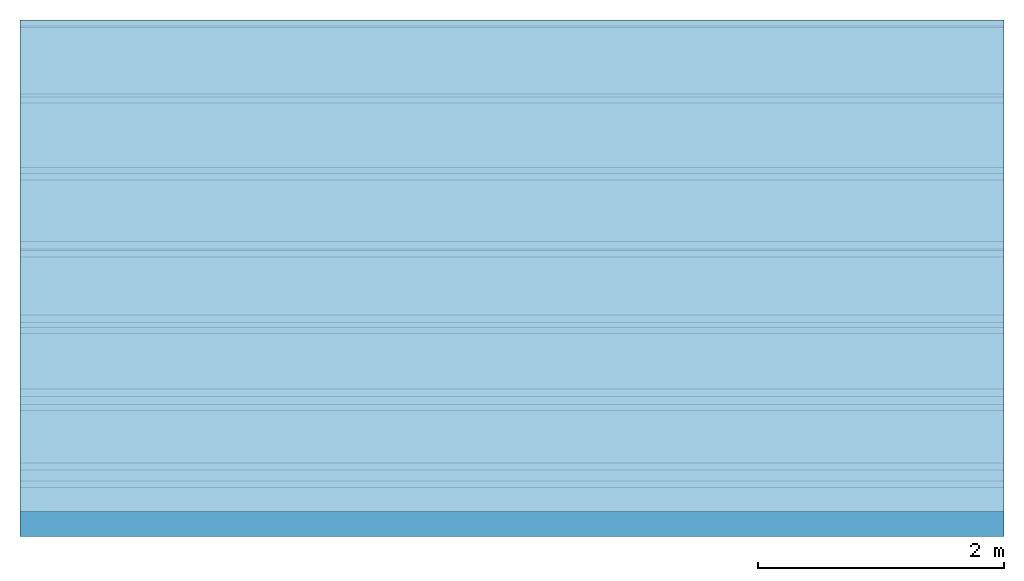
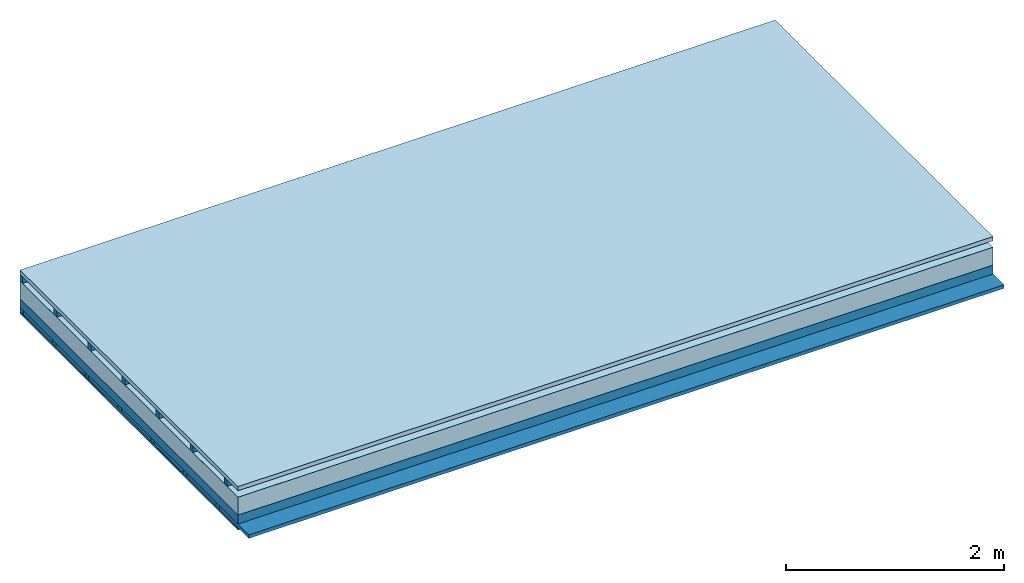
# One storey: 5 plates, 4 members, 1 element without a shape of its own.
"""IFC4 building model written with IfcOpenShell, lengths in metres."""

from ifc_helpers import new_model, si_unit, derived_unit, direction, frame, frame_2d, origin, origin_with_axes, place, context, project, spatial, rectangle, extrude, material, layer, layer_set, type_object, element, aggregate, save


model = new_model("IFC4")

# Units and contexts
plan_context = context("Plan", 3, precision=1e-05, world=origin(), true_north=direction((0.0, 1.0)))
model_context = context("Model", 3, precision=1e-05, world=origin(), true_north=direction((0.0, 1.0)))
ifc_project = project(units=[si_unit("LENGTHUNIT", "METRE"), derived_unit("SOUNDPRESSUREUNIT", [(si_unit("PRESSUREUNIT", "PASCAL", prefix="MICRO"), 0)]), si_unit("ENERGYUNIT", "JOULE", prefix="MEGA"), si_unit("MASSUNIT", "GRAM", prefix="KILO"), derived_unit("THERMALTRANSMITTANCEUNIT", [(si_unit("POWERUNIT", "WATT"), 1), (si_unit("AREAUNIT", "SQUARE_METRE"), -1), (si_unit("THERMODYNAMICTEMPERATUREUNIT", "KELVIN"), -1)]), derived_unit("AREADENSITYUNIT", [(si_unit("MASSUNIT", "GRAM", prefix="KILO"), 1), (si_unit("AREAUNIT", "SQUARE_METRE"), -1)]), derived_unit("USERDEFINED", [(si_unit("ENERGYUNIT", "JOULE", prefix="MEGA"), 1), (si_unit("AREAUNIT", "SQUARE_METRE"), -1)])], contexts=[plan_context, model_context])

# Site, building, storey
site = spatial("IfcSite", under=ifc_project)
building_placement = place(None, origin())
building = spatial("IfcBuilding", under=site, at=building_placement)
storey_placement = place(building_placement, origin())
storey = spatial("IfcBuildingStorey", under=building, at=storey_placement)

# Slab, members, plates
ifc_material_1 = material(Name="Roof tiles", Category="03.015")
ifc_layer_1 = layer(ifc_material_1, 0.047, Name="Roofing")
ifc_layer_2 = layer(None, 0.072, Name="Battens / profiles")
ifc_material_2 = material(Name="Roofing underlay", Category="09.008")
ifc_layer_3 = layer(ifc_material_2, 0.00018, Name="Under the roof")
ifc_material_3 = material(Category="10.009")
ifc_layer_4 = layer(ifc_material_3, 0.2, Name="Exterior insulation layer 1")
ifc_material_4 = material(Name="no composite action")
ifc_layer_5 = layer(ifc_material_4, 0.0, Name="Bond")
ifc_layer_6 = layer(None, 0.1, Name="Supporting structure")
ifc_material_5 = material(Name="of the art")
ifc_layer_7 = layer(ifc_material_5, 0.0, Name="Bond")
ifc_layer_8 = layer(None, 0.04, Name="Battens / profiles")
ifc_material_6 = material(Name="Plasterboard type A", Category="03.008")
ifc_layer_9 = layer(ifc_material_6, 0.015, Name="Covering below 1st layer")
ifc_layer_10 = layer(ifc_material_6, 0.015, Name="Covering below 2nd layer")
ifc_material_7 = material(Name="joints", Category="04.017")
ifc_layer_11 = layer(ifc_material_7, 0.0, Name="Surface below")
ifc_layer_set = layer_set([ifc_layer_1, ifc_layer_2, ifc_layer_3, ifc_layer_4, ifc_layer_5, ifc_layer_6, ifc_layer_7, ifc_layer_8, ifc_layer_9, ifc_layer_10, ifc_layer_11])
slab_type = type_object("IfcSlabType", Name="E0137", PredefinedType="NOTDEFINED", material=ifc_layer_set)
slab_placement = place(None, frame((0.0, 0.0, 0.0), z_axis=(0.0, 0.0, -1.0), x_axis=(1.0, 0.0, 0.0)))
slab = element("IfcSlab", 1, at=slab_placement, inside=storey, type_object=slab_type, material=ifc_layer_set, Name="Slab #1")
ifc_material_8 = material()
member_1_placement = place(slab_placement, origin())
member_1 = element("IfcMember", 2, at=member_1_placement, material=ifc_material_8, Name="Battens / profiles", context=plan_context, shape_type="SweptSolid", body=[
    extrude(rectangle(XDim=0.05, YDim=0.072, at=frame_2d((0.025, 0.036), x_axis=(1.0, 0.0))), frame((0.0, 0.0, 0.047), z_axis=(1.0, 0.0, 0.0), x_axis=(0.0, 1.0, 0.0)), (0.0, 0.0, 1.0), 8.0),
    extrude(rectangle(XDim=0.05, YDim=0.072, at=frame_2d((0.025, 0.036), x_axis=(1.0, 0.0))), frame((0.0, 0.625, 0.047), z_axis=(1.0, 0.0, 0.0), x_axis=(0.0, 1.0, 0.0)), (0.0, 0.0, 1.0), 8.0),
    extrude(rectangle(XDim=0.05, YDim=0.072, at=frame_2d((0.025, 0.036), x_axis=(1.0, 0.0))), frame((0.0, 1.25, 0.047), z_axis=(1.0, 0.0, 0.0), x_axis=(0.0, 1.0, 0.0)), (0.0, 0.0, 1.0), 8.0),
    extrude(rectangle(XDim=0.05, YDim=0.072, at=frame_2d((0.025, 0.036), x_axis=(1.0, 0.0))), frame((0.0, 1.875, 0.047), z_axis=(1.0, 0.0, 0.0), x_axis=(0.0, 1.0, 0.0)), (0.0, 0.0, 1.0), 8.0),
    extrude(rectangle(XDim=0.05, YDim=0.072, at=frame_2d((0.025, 0.036), x_axis=(1.0, 0.0))), frame((0.0, 2.5, 0.047), z_axis=(1.0, 0.0, 0.0), x_axis=(0.0, 1.0, 0.0)), (0.0, 0.0, 1.0), 8.0),
    extrude(rectangle(XDim=0.05, YDim=0.072, at=frame_2d((0.025, 0.036), x_axis=(1.0, 0.0))), frame((0.0, 3.125, 0.047), z_axis=(1.0, 0.0, 0.0), x_axis=(0.0, 1.0, 0.0)), (0.0, 0.0, 1.0), 8.0),
    extrude(rectangle(XDim=0.05, YDim=0.072, at=frame_2d((0.025, 0.036), x_axis=(1.0, 0.0))), frame((0.0, 3.75, 0.047), z_axis=(1.0, 0.0, 0.0), x_axis=(0.0, 1.0, 0.0)), (0.0, 0.0, 1.0), 8.0),
])
ifc_material_9 = material()
member_2_placement = place(slab_placement, origin())
member_2 = element("IfcMember", 3, at=member_2_placement, material=ifc_material_9, Name="Supporting structure", context=plan_context, shape_type="SweptSolid", body=[
    extrude(rectangle(XDim=1.0, YDim=0.1, at=frame_2d((0.5, 0.05), x_axis=(1.0, 0.0))), frame((0.0, 4.0, 0.31918), z_axis=(0.0, -1.0, 0.0), x_axis=(1.0, 0.0, 0.0)), (0.0, 0.0, 1.0), 4.0),
    extrude(rectangle(XDim=1.0, YDim=0.1, at=frame_2d((0.5, 0.05), x_axis=(1.0, 0.0))), frame((1.0, 4.0, 0.31918), z_axis=(0.0, -1.0, 0.0), x_axis=(1.0, 0.0, 0.0)), (0.0, 0.0, 1.0), 4.0),
    extrude(rectangle(XDim=1.0, YDim=0.1, at=frame_2d((0.5, 0.05), x_axis=(1.0, 0.0))), frame((2.0, 4.0, 0.31918), z_axis=(0.0, -1.0, 0.0), x_axis=(1.0, 0.0, 0.0)), (0.0, 0.0, 1.0), 4.0),
    extrude(rectangle(XDim=1.0, YDim=0.1, at=frame_2d((0.5, 0.05), x_axis=(1.0, 0.0))), frame((3.0, 4.0, 0.31918), z_axis=(0.0, -1.0, 0.0), x_axis=(1.0, 0.0, 0.0)), (0.0, 0.0, 1.0), 4.0),
    extrude(rectangle(XDim=1.0, YDim=0.1, at=frame_2d((0.5, 0.05), x_axis=(1.0, 0.0))), frame((4.0, 4.0, 0.31918), z_axis=(0.0, -1.0, 0.0), x_axis=(1.0, 0.0, 0.0)), (0.0, 0.0, 1.0), 4.0),
    extrude(rectangle(XDim=1.0, YDim=0.1, at=frame_2d((0.5, 0.05), x_axis=(1.0, 0.0))), frame((5.0, 4.0, 0.31918), z_axis=(0.0, -1.0, 0.0), x_axis=(1.0, 0.0, 0.0)), (0.0, 0.0, 1.0), 4.0),
    extrude(rectangle(XDim=1.0, YDim=0.1, at=frame_2d((0.5, 0.05), x_axis=(1.0, 0.0))), frame((6.0, 4.0, 0.31918), z_axis=(0.0, -1.0, 0.0), x_axis=(1.0, 0.0, 0.0)), (0.0, 0.0, 1.0), 4.0),
    extrude(rectangle(XDim=1.0, YDim=0.1, at=frame_2d((0.5, 0.05), x_axis=(1.0, 0.0))), frame((7.0, 4.0, 0.31918), z_axis=(0.0, -1.0, 0.0), x_axis=(1.0, 0.0, 0.0)), (0.0, 0.0, 1.0), 4.0),
])
ifc_material_10 = material()
member_3_placement = place(slab_placement, origin())
member_3 = element("IfcMember", 4, at=member_3_placement, material=ifc_material_10, Name="Battens / profiles", context=plan_context, shape_type="SweptSolid", body=[
    extrude(rectangle(XDim=0.06, YDim=0.04, at=frame_2d((0.03, 0.02), x_axis=(1.0, 0.0))), frame((0.0, 0.0, 0.41918), z_axis=(1.0, 0.0, 0.0), x_axis=(0.0, 1.0, 0.0)), (0.0, 0.0, 1.0), 8.0),
    extrude(rectangle(XDim=0.06, YDim=0.04, at=frame_2d((0.03, 0.02), x_axis=(1.0, 0.0))), frame((0.0, 0.6, 0.41918), z_axis=(1.0, 0.0, 0.0), x_axis=(0.0, 1.0, 0.0)), (0.0, 0.0, 1.0), 8.0),
    extrude(rectangle(XDim=0.06, YDim=0.04, at=frame_2d((0.03, 0.02), x_axis=(1.0, 0.0))), frame((0.0, 1.2, 0.41918), z_axis=(1.0, 0.0, 0.0), x_axis=(0.0, 1.0, 0.0)), (0.0, 0.0, 1.0), 8.0),
    extrude(rectangle(XDim=0.06, YDim=0.04, at=frame_2d((0.03, 0.02), x_axis=(1.0, 0.0))), frame((0.0, 1.8, 0.41918), z_axis=(1.0, 0.0, 0.0), x_axis=(0.0, 1.0, 0.0)), (0.0, 0.0, 1.0), 8.0),
    extrude(rectangle(XDim=0.06, YDim=0.04, at=frame_2d((0.03, 0.02), x_axis=(1.0, 0.0))), frame((0.0, 2.4, 0.41918), z_axis=(1.0, 0.0, 0.0), x_axis=(0.0, 1.0, 0.0)), (0.0, 0.0, 1.0), 8.0),
    extrude(rectangle(XDim=0.06, YDim=0.04, at=frame_2d((0.03, 0.02), x_axis=(1.0, 0.0))), frame((0.0, 3.0, 0.41918), z_axis=(1.0, 0.0, 0.0), x_axis=(0.0, 1.0, 0.0)), (0.0, 0.0, 1.0), 8.0),
    extrude(rectangle(XDim=0.06, YDim=0.04, at=frame_2d((0.03, 0.02), x_axis=(1.0, 0.0))), frame((0.0, 3.6, 0.41918), z_axis=(1.0, 0.0, 0.0), x_axis=(0.0, 1.0, 0.0)), (0.0, 0.0, 1.0), 8.0),
])
ifc_material_11 = material(Name="Mineral wool")
member_4_placement = place(slab_placement, origin())
member_4 = element("IfcMember", 5, at=member_4_placement, material=ifc_material_11, Name="Cavity", context=plan_context, shape_type="SweptSolid", body=[
    extrude(rectangle(XDim=0.54, YDim=0.04, at=frame_2d((0.27, 0.02), x_axis=(1.0, 0.0))), frame((0.0, 0.06, 0.41918), z_axis=(1.0, 0.0, 0.0), x_axis=(0.0, 1.0, 0.0)), (0.0, 0.0, 1.0), 8.0),
    extrude(rectangle(XDim=0.54, YDim=0.04, at=frame_2d((0.27, 0.02), x_axis=(1.0, 0.0))), frame((0.0, 0.66, 0.41918), z_axis=(1.0, 0.0, 0.0), x_axis=(0.0, 1.0, 0.0)), (0.0, 0.0, 1.0), 8.0),
    extrude(rectangle(XDim=0.54, YDim=0.04, at=frame_2d((0.27, 0.02), x_axis=(1.0, 0.0))), frame((0.0, 1.26, 0.41918), z_axis=(1.0, 0.0, 0.0), x_axis=(0.0, 1.0, 0.0)), (0.0, 0.0, 1.0), 8.0),
    extrude(rectangle(XDim=0.54, YDim=0.04, at=frame_2d((0.27, 0.02), x_axis=(1.0, 0.0))), frame((0.0, 1.86, 0.41918), z_axis=(1.0, 0.0, 0.0), x_axis=(0.0, 1.0, 0.0)), (0.0, 0.0, 1.0), 8.0),
    extrude(rectangle(XDim=0.54, YDim=0.04, at=frame_2d((0.27, 0.02), x_axis=(1.0, 0.0))), frame((0.0, 2.46, 0.41918), z_axis=(1.0, 0.0, 0.0), x_axis=(0.0, 1.0, 0.0)), (0.0, 0.0, 1.0), 8.0),
    extrude(rectangle(XDim=0.54, YDim=0.04, at=frame_2d((0.27, 0.02), x_axis=(1.0, 0.0))), frame((0.0, 3.06, 0.41918), z_axis=(1.0, 0.0, 0.0), x_axis=(0.0, 1.0, 0.0)), (0.0, 0.0, 1.0), 8.0),
    extrude(rectangle(XDim=0.54, YDim=0.04, at=frame_2d((0.27, 0.02), x_axis=(1.0, 0.0))), frame((0.0, 3.66, 0.41918), z_axis=(1.0, 0.0, 0.0), x_axis=(0.0, 1.0, 0.0)), (0.0, 0.0, 1.0), 8.0),
])
plate_1_placement = place(slab_placement, origin())
plate_1 = element("IfcPlate", 6, at=plate_1_placement, material=ifc_material_1, Name="Roofing", context=plan_context, shape_type="SweptSolid", body=[
    extrude(rectangle(XDim=8.0, YDim=4.0, at=frame_2d((4.0, 2.0), x_axis=(1.0, 0.0))), origin_with_axes(), (0.0, 0.0, 1.0), 0.047),
])
plate_2_placement = place(slab_placement, origin())
plate_2 = element("IfcPlate", 7, at=plate_2_placement, material=ifc_material_2, Name="Under the roof", context=plan_context, shape_type="SweptSolid", body=[
    extrude(rectangle(XDim=8.0, YDim=4.0, at=frame_2d((4.0, 2.0), x_axis=(1.0, 0.0))), frame((0.0, 0.0, 0.119), z_axis=(0.0, 0.0, 1.0), x_axis=(1.0, 0.0, 0.0)), (0.0, 0.0, 1.0), 0.00018),
])
plate_3_placement = place(slab_placement, origin())
plate_3 = element("IfcPlate", 8, at=plate_3_placement, material=ifc_material_3, Name="Exterior insulation layer 1", context=plan_context, shape_type="SweptSolid", body=[
    extrude(rectangle(XDim=8.0, YDim=4.0, at=frame_2d((4.0, 2.0), x_axis=(1.0, 0.0))), frame((0.0, 0.0, 0.11918), z_axis=(0.0, 0.0, 1.0), x_axis=(1.0, 0.0, 0.0)), (0.0, 0.0, 1.0), 0.2),
])
plate_4_placement = place(slab_placement, origin())
plate_4 = element("IfcPlate", 9, at=plate_4_placement, material=ifc_material_6, Name="Covering below 1st layer", context=plan_context, shape_type="SweptSolid", body=[
    extrude(rectangle(XDim=8.0, YDim=4.0, at=frame_2d((4.0, 2.0), x_axis=(1.0, 0.0))), frame((0.0, 0.0, 0.45918), z_axis=(0.0, 0.0, 1.0), x_axis=(1.0, 0.0, 0.0)), (0.0, 0.0, 1.0), 0.015),
])
plate_5_placement = place(slab_placement, origin())
plate_5 = element("IfcPlate", 10, at=plate_5_placement, material=ifc_material_6, Name="Covering below 2nd layer", context=plan_context, shape_type="SweptSolid", body=[
    extrude(rectangle(XDim=8.0, YDim=4.0, at=frame_2d((4.0, 2.0), x_axis=(1.0, 0.0))), frame((0.0, 0.0, 0.47418), z_axis=(0.0, 0.0, 1.0), x_axis=(1.0, 0.0, 0.0)), (0.0, 0.0, 1.0), 0.015),
])
aggregate(slab, [plate_1, member_1, plate_2, plate_3, member_2, member_3, member_4, plate_4, plate_5])

save(model, "model.ifc")
